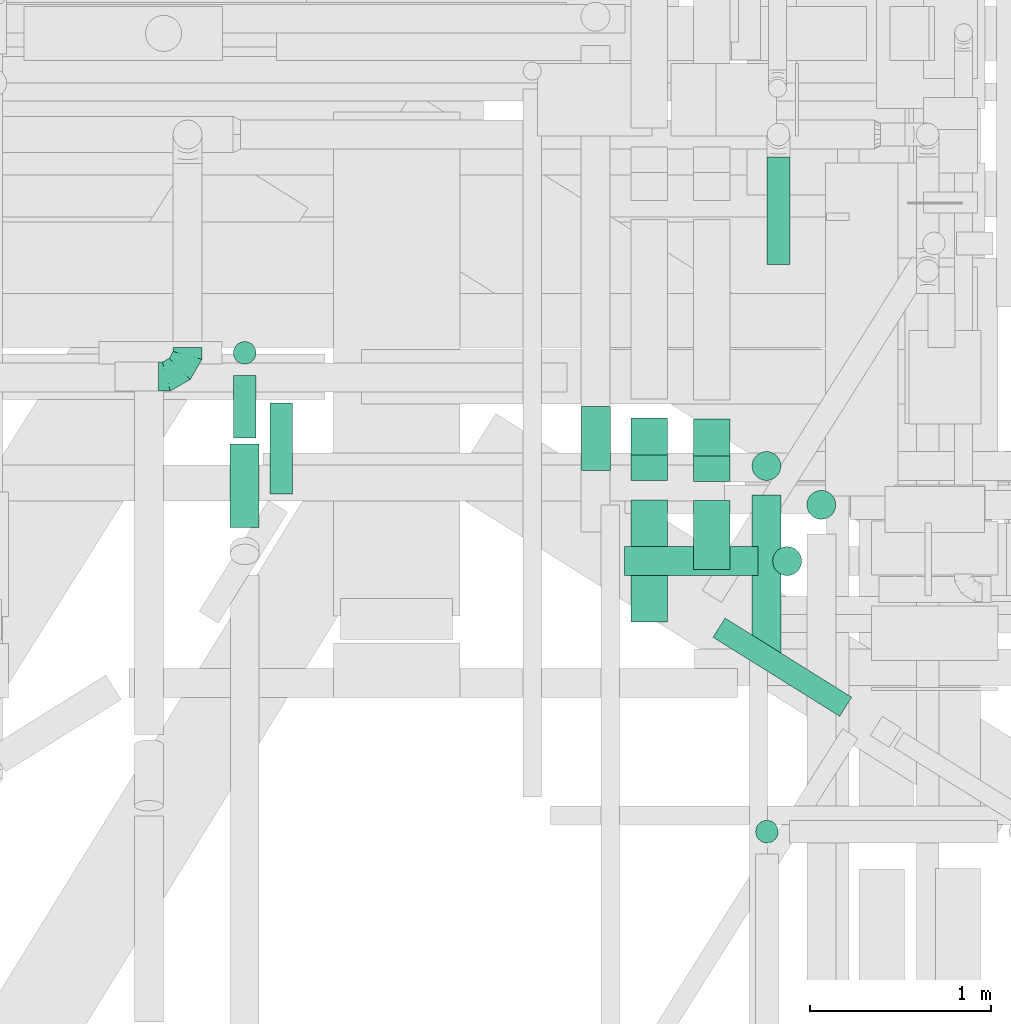
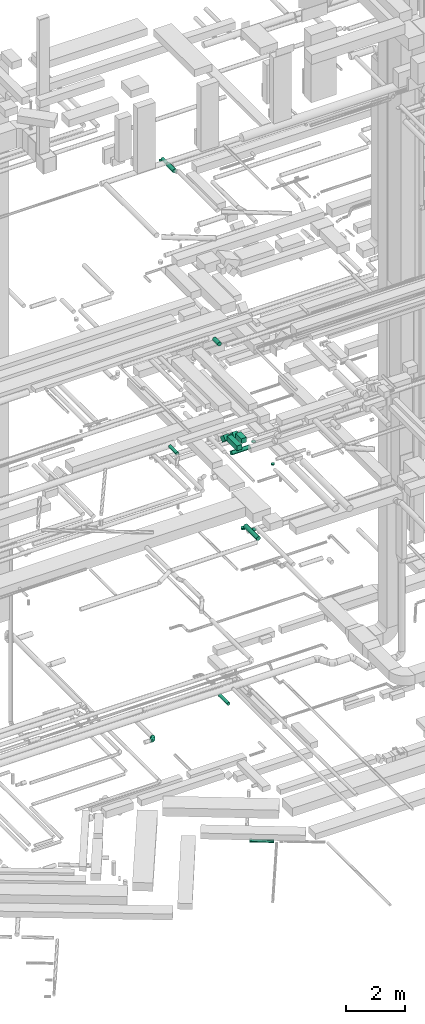
# One storey, part 102 of 337: 17 flow segments, 1 flow fitting.
"""IFC2X3 building model written with IfcOpenShell, lengths in millimetres."""

from ifc_helpers import new_model, entity, si_unit, converted_unit, derived_unit, direction, frame, frame_2d, origin, origin_2d_with_axis, place, context, subcontext, project, spatial, rectangle, circle, extrude, faceted_brep, source, transform, mapped, material, type_object, type_shapes, element, save


model = new_model("IFC2X3")

# Units and contexts
model_context = context("Model", 3, precision=0.01, world=origin(), true_north=direction((6.12303176911189e-17, 1.0)))
body_context = subcontext(model_context, "Body", "Model", "MODEL_VIEW")
ifc_project = project(units=[si_unit("LENGTHUNIT", "METRE", prefix="MILLI"), si_unit("AREAUNIT", "SQUARE_METRE"), si_unit("VOLUMEUNIT", "CUBIC_METRE"), converted_unit("PLANEANGLEUNIT", "DEGREE", entity("IfcRatioMeasure", 0.0174532925199433), si_unit("PLANEANGLEUNIT", "RADIAN"), dimensions=[0, 0, 0, 0, 0, 0, 0]), si_unit("MASSUNIT", "GRAM", prefix="KILO"), derived_unit("MASSDENSITYUNIT", [(si_unit("MASSUNIT", "GRAM", prefix="KILO"), 1), (si_unit("LENGTHUNIT", "METRE"), -3)]), derived_unit("MOMENTOFINERTIAUNIT", [(si_unit("LENGTHUNIT", "METRE"), 4)]), si_unit("TIMEUNIT", "SECOND"), si_unit("FREQUENCYUNIT", "HERTZ"), si_unit("THERMODYNAMICTEMPERATUREUNIT", "DEGREE_CELSIUS"), derived_unit("THERMALTRANSMITTANCEUNIT", [(si_unit("MASSUNIT", "GRAM", prefix="KILO"), 1), (si_unit("THERMODYNAMICTEMPERATUREUNIT", "KELVIN"), -1), (si_unit("TIMEUNIT", "SECOND"), -3)]), derived_unit("VOLUMETRICFLOWRATEUNIT", [(si_unit("LENGTHUNIT", "METRE"), 3), (si_unit("TIMEUNIT", "SECOND"), -1)]), derived_unit("MASSFLOWRATEUNIT", [(si_unit("MASSUNIT", "GRAM", prefix="KILO"), 1), (si_unit("TIMEUNIT", "SECOND"), -1)]), derived_unit("ROTATIONALFREQUENCYUNIT", [(si_unit("TIMEUNIT", "SECOND"), -1)]), si_unit("ELECTRICCURRENTUNIT", "AMPERE"), si_unit("ELECTRICVOLTAGEUNIT", "VOLT"), si_unit("POWERUNIT", "WATT"), si_unit("FORCEUNIT", "NEWTON", prefix="KILO"), si_unit("ILLUMINANCEUNIT", "LUX"), si_unit("LUMINOUSFLUXUNIT", "LUMEN"), si_unit("LUMINOUSINTENSITYUNIT", "CANDELA"), derived_unit("USERDEFINED", [(si_unit("MASSUNIT", "GRAM", prefix="KILO"), -1), (si_unit("LENGTHUNIT", "METRE"), -2), (si_unit("TIMEUNIT", "SECOND"), 3), (si_unit("LUMINOUSFLUXUNIT", "LUMEN"), 1)]), derived_unit("LINEARVELOCITYUNIT", [(si_unit("LENGTHUNIT", "METRE"), 1), (si_unit("TIMEUNIT", "SECOND"), -1)]), si_unit("PRESSUREUNIT", "PASCAL"), derived_unit("USERDEFINED", [(si_unit("LENGTHUNIT", "METRE"), -2), (si_unit("MASSUNIT", "GRAM", prefix="KILO"), 1), (si_unit("TIMEUNIT", "SECOND"), -2)]), derived_unit("LINEARFORCEUNIT", [(si_unit("MASSUNIT", "GRAM", prefix="KILO"), 1), (si_unit("LENGTHUNIT", "METRE"), 1), (si_unit("TIMEUNIT", "SECOND"), -2), (si_unit("LENGTHUNIT", "METRE"), -1)]), derived_unit("PLANARFORCEUNIT", [(si_unit("MASSUNIT", "GRAM", prefix="KILO"), 1), (si_unit("LENGTHUNIT", "METRE"), 1), (si_unit("TIMEUNIT", "SECOND"), -2), (si_unit("LENGTHUNIT", "METRE"), -2)])], contexts=[model_context])

# Site, building, storey
site_placement = place(None, origin())
site = spatial("IfcSite", under=ifc_project, at=site_placement, CompositionType="ELEMENT")
building_placement = place(site_placement, origin())
building = spatial("IfcBuilding", under=site, at=building_placement, CompositionType="ELEMENT")
storey_placement = place(building_placement, origin())
storey = spatial("IfcBuildingStorey", under=building, at=storey_placement, CompositionType="ELEMENT", Elevation=0.0)

# Flow segments
duct_segment_type_1 = type_object("IfcDuctSegmentType", PredefinedType="NOTDEFINED")
flow_segment_1_placement = place(storey_placement, frame((16784.94, 9378.26, 15250.0)))
element("IfcFlowSegment", 1, at=flow_segment_1_placement, inside=storey, type_object=duct_segment_type_1, context=body_context, shape_type="SweptSolid", body=[
    extrude(rectangle(XDim=676.446601535237, YDim=200.0, at=origin_2d_with_axis()), frame((100.0, 338.22, 0.0), z_axis=(0.0, 0.0, 1.0), x_axis=(0.0, 1.0, 0.0)), (0.0, 0.0, 1.0), 200.000000000002),
])
flow_segment_2_placement = place(storey_placement, frame((17130.0, 9670.0, 15250.0)))
element("IfcFlowSegment", 2, at=flow_segment_2_placement, inside=storey, type_object=duct_segment_type_1, context=body_context, shape_type="SweptSolid", body=[
    extrude(rectangle(XDim=380.446604650265, YDim=200.0, at=origin_2d_with_axis()), frame((100.0, 190.22, 0.0), z_axis=(0.0, 0.0, 1.0), x_axis=(0.0, 1.0, 0.0)), (0.0, 0.0, 1.0), 200.000000000002),
])
flow_segment_3_placement = place(storey_placement, frame((17130.0, 10156.51, 15002.51)))
element("IfcFlowSegment", 3, at=flow_segment_3_placement, inside=storey, type_object=duct_segment_type_1, context=body_context, shape_type="SweptSolid", body=[
    extrude(rectangle(XDim=199.999999999999, YDim=200.000000000002, at=frame_2d((0.0, 0.0), x_axis=(0.0, 1.0))), frame((100.0, 274.26, 70.71), z_axis=(0.0, -0.707106781186504, 0.707106781186591), x_axis=(1.0, 0.0, 0.0)), (0.0, 0.0, 1.0), 287.867965643974),
])
flow_segment_4_placement = place(storey_placement, frame((16784.94, 10160.77, 15002.51)))
element("IfcFlowSegment", 4, at=flow_segment_4_placement, inside=storey, type_object=duct_segment_type_1, context=body_context, shape_type="SweptSolid", body=[
    extrude(rectangle(XDim=199.999999999999, YDim=199.999999999998, at=frame_2d((0.0, 0.0), x_axis=(0.0, 1.0))), frame((100.0, 274.26, 70.71), z_axis=(0.0, -0.707106781186504, 0.707106781186591), x_axis=(1.0, 0.0, 0.0)), (0.0, 0.0, 1.0), 287.867965644037),
])
duct_segment_type_2 = type_object("IfcDuctSegmentType", PredefinedType="NOTDEFINED")
flow_segment_5_placement = place(storey_placement, frame((17235.81, 8855.41, -1164.1)))
element("IfcFlowSegment", 5, at=flow_segment_5_placement, inside=storey, type_object=duct_segment_type_2, context=body_context, shape_type="SweptSolid", body=[
    extrude(circle(Radius=62.5, at=origin_2d_with_axis()), frame((734.95, 54.6, 64.1), z_axis=(-0.848048096156446, 0.529919264233173, 0.0), x_axis=(0.529919264233173, 0.848048096156446, 0.0)), (0.0, 0.0, 1.0), 825.69674156195),
])
flow_segment_6_placement = place(storey_placement, frame((17754.62, 9945.1, 11225.0)))
element("IfcFlowSegment", 6, at=flow_segment_6_placement, inside=storey, type_object=duct_segment_type_2, context=body_context, shape_type="SweptSolid", body=[
    extrude(circle(Radius=80.0, at=origin_2d_with_axis()), frame((81.6, 81.6, 0.0), z_axis=(0.0, 0.0, 1.0), x_axis=(-1.0, 0.0, 0.0)), (0.0, 0.0, 1.0), 15.0000000000074),
])
flow_segment_7_placement = place(storey_placement, frame((17451.16, 9201.51, 11368.4)))
element("IfcFlowSegment", 7, at=flow_segment_7_placement, inside=storey, type_object=duct_segment_type_2, context=body_context, shape_type="SweptSolid", body=[
    extrude(circle(Radius=80.0, at=origin_2d_with_axis()), frame((81.6, 0.0, 81.6), z_axis=(0.0, 1.0, 0.0), x_axis=(-1.0, 0.0, 0.0)), (0.0, 0.0, 1.0), 880.000000000072),
])
flow_segment_8_placement = place(storey_placement, frame((17451.16, 10159.92, 11225.0)))
element("IfcFlowSegment", 8, at=flow_segment_8_placement, inside=storey, type_object=duct_segment_type_2, context=body_context, shape_type="SweptSolid", body=[
    extrude(circle(Radius=80.0, at=origin_2d_with_axis()), frame((81.6, 81.6, 0.0), z_axis=(0.0, 0.0, 1.0), x_axis=(-1.0, 0.0, 0.0)), (0.0, 0.0, 1.0), 65.0000000000285),
])
flow_segment_9_placement = place(storey_placement, frame((17535.1, 11354.54, 3185.9)))
element("IfcFlowSegment", 9, at=flow_segment_9_placement, inside=storey, type_object=duct_segment_type_2, context=body_context, shape_type="SweptSolid", body=[
    extrude(circle(Radius=62.5, at=origin_2d_with_axis()), frame((64.1, 0.0, 64.1), z_axis=(0.0, 1.0, 0.0), x_axis=(-1.0, 0.0, 0.0)), (0.0, 0.0, 1.0), 595.00000000001),
])
flow_segment_10_placement = place(storey_placement, frame((14786.5, 10085.54, 15323.4)))
element("IfcFlowSegment", 10, at=flow_segment_10_placement, inside=storey, type_object=duct_segment_type_2, context=body_context, shape_type="SweptSolid", body=[
    extrude(circle(Radius=62.5, at=origin_2d_with_axis()), frame((64.1, 0.0, 64.1), z_axis=(0.0, 1.0, 0.0), x_axis=(1.0, 0.0, 0.0)), (0.0, 0.0, 1.0), 504.094382091789),
])
flow_segment_11_placement = place(storey_placement, frame((16747.22, 9634.09, 14888.4)))
element("IfcFlowSegment", 11, at=flow_segment_11_placement, inside=storey, type_object=duct_segment_type_2, context=body_context, shape_type="SweptSolid", body=[
    extrude(circle(Radius=80.0, at=origin_2d_with_axis()), frame((0.0, 81.6, 81.6), z_axis=(1.0, 0.0, 0.0), x_axis=(0.0, 1.0, 0.0)), (0.0, 0.0, 1.0), 740.000000000016),
])
flow_segment_12_placement = place(storey_placement, frame((17565.63, 9634.09, 15130.0)))
element("IfcFlowSegment", 12, at=flow_segment_12_placement, inside=storey, type_object=duct_segment_type_2, context=body_context, shape_type="SweptSolid", body=[
    extrude(circle(Radius=80.0, at=origin_2d_with_axis()), frame((81.6, 81.6, 0.0), z_axis=(0.0, 0.0, 1.0), x_axis=(0.0, 1.0, 0.0)), (0.0, 0.0, 1.0), 10.0000593925115),
])
flow_segment_13_placement = place(storey_placement, frame((17471.46, 8155.54, 15125.0)))
element("IfcFlowSegment", 13, at=flow_segment_13_placement, inside=storey, type_object=duct_segment_type_2, context=body_context, shape_type="SweptSolid", body=[
    extrude(circle(Radius=62.5, at=origin_2d_with_axis()), frame((64.1, 64.1, 0.0), z_axis=(0.0, 0.0, 1.0), x_axis=(-1.0, 0.0, 0.0)), (0.0, 0.0, 1.0), 49.9999952435056),
])
flow_segment_14_placement = place(storey_placement, frame((16508.41, 10217.12, 19168.4)))
element("IfcFlowSegment", 14, at=flow_segment_14_placement, inside=storey, type_object=duct_segment_type_2, context=body_context, shape_type="SweptSolid", body=[
    extrude(circle(Radius=80.0, at=origin_2d_with_axis()), frame((81.6, 0.0, 81.6), z_axis=(0.0, 1.0, 0.0), x_axis=(-1.0, 0.0, 0.0)), (0.0, 0.0, 1.0), 354.69000286633),
])
flow_segment_15_placement = place(storey_placement, frame((14583.33, 10397.13, 27255.9)))
element("IfcFlowSegment", 15, at=flow_segment_15_placement, inside=storey, type_object=duct_segment_type_2, context=body_context, shape_type="SweptSolid", body=[
    extrude(circle(Radius=62.5, at=origin_2d_with_axis()), frame((64.1, 0.0, 64.1), z_axis=(0.0, 1.0, 0.0), x_axis=(-1.0, 0.0, 0.0)), (0.0, 0.0, 1.0), 344.999999999989),
])
flow_segment_16_placement = place(storey_placement, frame((14583.33, 10803.03, 27175.0)))
element("IfcFlowSegment", 16, at=flow_segment_16_placement, inside=storey, type_object=duct_segment_type_2, context=body_context, shape_type="SweptSolid", body=[
    extrude(circle(Radius=62.5, at=origin_2d_with_axis()), frame((64.1, 64.1, 0.0), z_axis=(0.0, 0.0, 1.0), x_axis=(-1.0, 0.0, 0.0)), (0.0, 0.0, 1.0), 19.9999999999955),
])
flow_segment_17_placement = place(storey_placement, frame((14565.83, 9902.41, 27238.4)))
element("IfcFlowSegment", 17, at=flow_segment_17_placement, inside=storey, type_object=duct_segment_type_2, context=body_context, shape_type="SweptSolid", body=[
    extrude(circle(Radius=80.0, at=origin_2d_with_axis()), frame((81.6, 0.0, 81.6), z_axis=(0.0, 1.0, 0.0), x_axis=(-1.0, 0.0, 0.0)), (0.0, 0.0, 1.0), 459.719921124507),
])

# Flow fitting
ifc_material = material()
duct_fitting_type = type_object("IfcDuctFittingType", PredefinedType="NOTDEFINED", material=ifc_material)
shared_shape = source(origin(), body_context, "Body", "Brep", [
    faceted_brep([(-160.0, 0.0, -80.0), (-160.0, -20.71, -77.27), (-160.0, -40.0, -69.28), (-160.0, -56.57, -56.57), (-160.0, -69.28, -40.0), (-160.0, -77.27, -20.71), (-160.0, -80.0, 0.0), (-160.0, -77.27, 20.71), (-160.0, -69.28, 40.0), (-160.0, -56.57, 56.57), (-160.0, -40.0, 69.28), (-160.0, -20.71, 77.27), (-160.0, 0.0, 80.0), (-160.0, 20.71, 77.27), (-160.0, 40.0, 69.28), (-160.0, 56.57, 56.57), (-160.0, 69.28, 40.0), (-160.0, 77.27, 20.71), (-160.0, 80.0, 0.0), (-160.0, 77.27, -20.71), (-160.0, 69.28, -40.0), (-160.0, 56.57, -56.57), (-160.0, 40.0, -69.28), (-160.0, 20.71, -77.27), (-122.68, 20.71, 77.27), (-127.85, 40.0, 69.28), (-117.13, 0.0, 80.0), (-132.29, 56.57, 56.57), (-137.83, 77.27, 20.71), (-138.56, 80.0, 0.0), (-135.69, 69.28, 40.0), (-135.69, 69.28, -40.0), (-132.29, 56.57, -56.57), (-137.83, 77.27, -20.71), (-122.68, 20.71, -77.27), (-117.13, 0.0, -80.0), (-127.85, 40.0, -69.28), (-111.58, -20.71, -77.27), (-106.41, -40.0, -69.28), (-101.97, -56.57, -56.57), (-98.56, -69.28, -40.0), (-96.42, -77.27, -20.71), (-95.69, -80.0, 0.0), (-96.42, -77.27, 20.71), (-98.56, -69.28, 40.0), (-101.97, -56.57, 56.57), (-106.41, -40.0, 69.28), (-111.58, -20.71, 77.27), (-58.03, 58.03, 77.27), (-72.15, 72.15, 69.28), (-42.87, 42.87, 80.0), (-84.28, 84.28, 56.57), (-93.59, 93.59, 40.0), (-99.44, 99.44, 20.71), (-101.44, 101.44, 0.0), (-99.44, 99.44, -20.71), (-93.59, 93.59, -40.0), (-84.28, 84.28, -56.57), (-58.03, 58.03, -77.27), (-42.87, 42.87, -80.0), (-72.15, 72.15, -69.28), (-27.71, 27.71, -77.27), (-13.59, 13.59, -69.28), (-1.46, 1.46, -56.57), (7.85, -7.85, -40.0), (13.7, -13.7, -20.71), (15.69, -15.69, 0.0), (13.7, -13.7, 20.71), (7.85, -7.85, 40.0), (-1.46, 1.46, 56.57), (-13.59, 13.59, 69.28), (-27.71, 27.71, 77.27), (-20.71, 122.68, 77.27), (-40.0, 127.85, 69.28), (0.0, 117.13, 80.0), (-56.57, 132.29, 56.57), (-69.28, 135.69, 40.0), (-77.27, 137.83, 20.71), (-80.0, 138.56, 0.0), (-77.27, 137.83, -20.71), (-69.28, 135.69, -40.0), (-56.57, 132.29, -56.57), (-20.71, 122.68, -77.27), (0.0, 117.13, -80.0), (-40.0, 127.85, -69.28), (20.71, 111.58, -77.27), (40.0, 106.41, -69.28), (56.57, 101.97, -56.57), (69.28, 98.56, -40.0), (77.27, 96.42, -20.71), (80.0, 95.69, 0.0), (77.27, 96.42, 20.71), (69.28, 98.56, 40.0), (56.57, 101.97, 56.57), (40.0, 106.41, 69.28), (20.71, 111.58, 77.27), (-20.71, 160.0, -77.27), (-40.0, 160.0, -69.28), (-56.57, 160.0, -56.57), (-69.28, 160.0, -40.0), (-77.27, 160.0, -20.71), (-80.0, 160.0, 0.0), (-77.27, 160.0, 20.71), (-69.28, 160.0, 40.0), (-56.57, 160.0, 56.57), (-40.0, 160.0, 69.28), (-20.71, 160.0, 77.27), (0.0, 160.0, 80.0), (20.71, 160.0, 77.27), (40.0, 160.0, 69.28), (56.57, 160.0, 56.57), (69.28, 160.0, 40.0), (77.27, 160.0, 20.71), (80.0, 160.0, 0.0), (77.27, 160.0, -20.71), (69.28, 160.0, -40.0), (56.57, 160.0, -56.57), (40.0, 160.0, -69.28), (20.71, 160.0, -77.27), (0.0, 160.0, -80.0)], [[[0, 1, 2, 3, 4, 5, 6, 7, 8, 9, 10, 11, 12, 13, 14, 15, 16, 17, 18, 19, 20, 21, 22, 23]], [[24, 25, 14, 13]], [[26, 24, 13, 12]], [[14, 25, 27, 15]], [[28, 29, 18, 17]], [[30, 28, 17, 16]], [[15, 27, 30, 16]], [[20, 31, 32, 21]], [[33, 31, 20, 19]], [[18, 29, 33, 19]], [[34, 35, 0, 23]], [[36, 34, 23, 22]], [[32, 36, 22, 21]], [[1, 0, 35, 37]], [[2, 1, 37, 38]], [[3, 2, 38, 39]], [[5, 4, 40, 41]], [[6, 5, 41, 42]], [[39, 40, 4, 3]], [[6, 42, 43, 7]], [[7, 43, 44, 8]], [[8, 44, 45, 9]], [[9, 45, 46, 10]], [[10, 46, 47, 11]], [[26, 12, 11, 47]], [[48, 49, 25, 24]], [[50, 48, 24, 26]], [[27, 25, 49, 51]], [[52, 53, 28, 30]], [[51, 52, 30, 27]], [[29, 28, 53, 54]], [[55, 56, 31, 33]], [[54, 55, 33, 29]], [[32, 31, 56, 57]], [[58, 59, 35, 34]], [[60, 58, 34, 36]], [[57, 60, 36, 32]], [[37, 35, 59, 61]], [[38, 37, 61, 62]], [[39, 38, 62, 63]], [[41, 40, 64, 65]], [[42, 41, 65, 66]], [[63, 64, 40, 39]], [[43, 42, 66, 67]], [[44, 43, 67, 68]], [[68, 69, 45, 44]], [[46, 45, 69, 70]], [[47, 46, 70, 71]], [[26, 47, 71, 50]], [[72, 73, 49, 48]], [[74, 72, 48, 50]], [[51, 49, 73, 75]], [[76, 77, 53, 52]], [[75, 76, 52, 51]], [[54, 53, 77, 78]], [[79, 80, 56, 55]], [[78, 79, 55, 54]], [[57, 56, 80, 81]], [[82, 83, 59, 58]], [[84, 82, 58, 60]], [[81, 84, 60, 57]], [[61, 59, 83, 85]], [[62, 61, 85, 86]], [[63, 62, 86, 87]], [[65, 64, 88, 89]], [[66, 65, 89, 90]], [[87, 88, 64, 63]], [[67, 66, 90, 91]], [[68, 67, 91, 92]], [[92, 93, 69, 68]], [[70, 69, 93, 94]], [[71, 70, 94, 95]], [[50, 71, 95, 74]], [[96, 97, 98, 99, 100, 101, 102, 103, 104, 105, 106, 107, 108, 109, 110, 111, 112, 113, 114, 115, 116, 117, 118, 119]], [[72, 74, 107, 106]], [[73, 72, 106, 105]], [[75, 73, 105, 104]], [[77, 76, 103, 102]], [[78, 77, 102, 101]], [[75, 104, 103, 76]], [[78, 101, 100, 79]], [[79, 100, 99, 80]], [[80, 99, 98, 81]], [[84, 97, 96, 82]], [[82, 96, 119, 83]], [[84, 81, 98, 97]], [[118, 117, 86, 85]], [[119, 118, 85, 83]], [[116, 87, 86, 117]], [[88, 115, 114, 89]], [[89, 114, 113, 90]], [[115, 88, 87, 116]], [[112, 111, 92, 91]], [[113, 112, 91, 90]], [[111, 110, 93, 92]], [[95, 94, 109, 108]], [[74, 95, 108, 107]], [[110, 109, 94, 93]]]),
])
type_shapes(duct_fitting_type, [shared_shape])
flow_fitting_placement = place(storey_placement, frame((14331.42, 10736.08, 3300.0)))
element("IfcFlowFitting", 18, at=flow_fitting_placement, inside=storey, type_object=duct_fitting_type, material=ifc_material, context=body_context, shape_type="MappedRepresentation", body=[
    mapped(shared_shape, transform((0.0, 0.0, 0.0), scale=1.0)),
])

save(model, "model.ifc")
